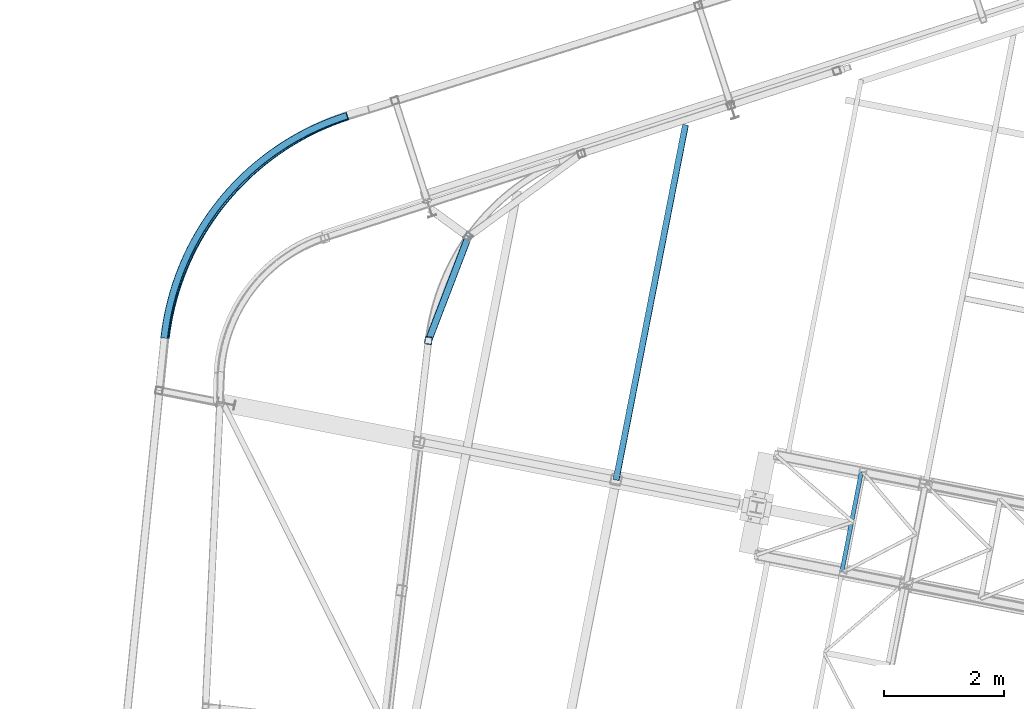
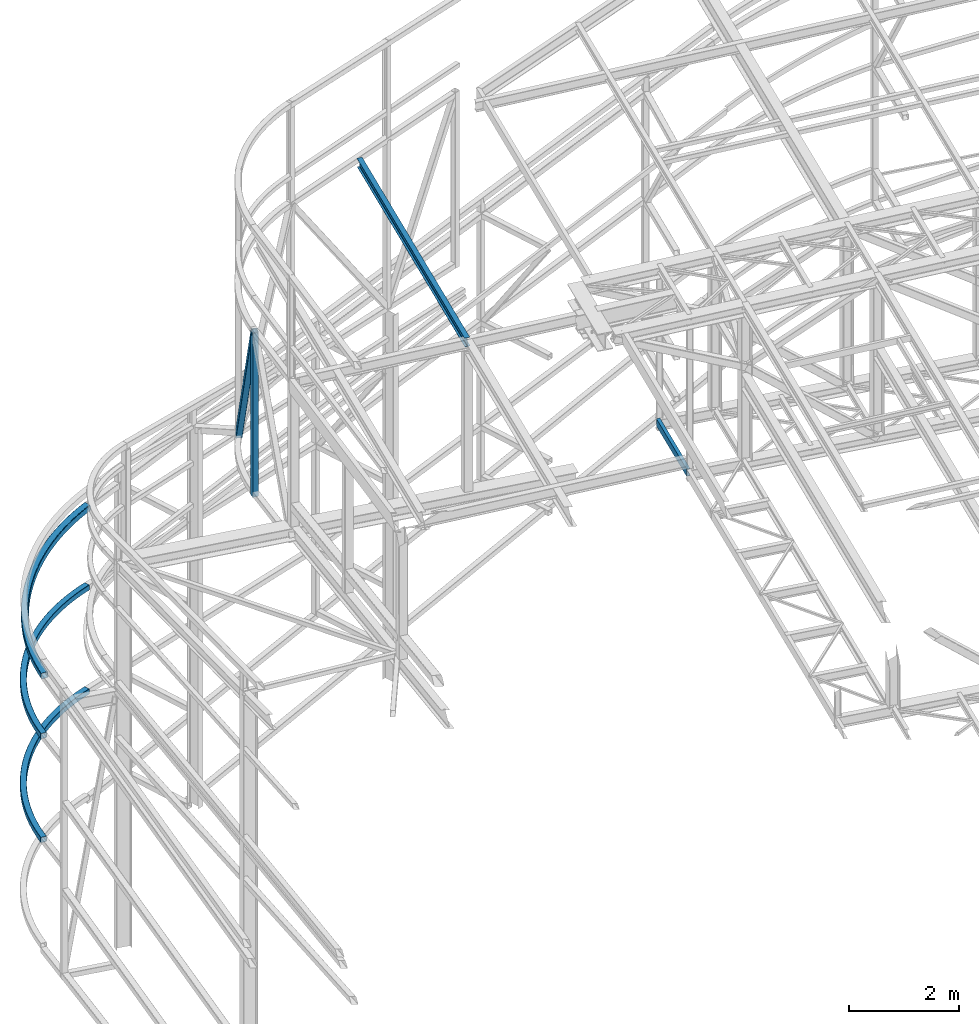
# One storey, part 78 of 215: 6 beams, 1 member, 7 elements without a shape of their own.
"""IFC2X3 building model written with IfcOpenShell, lengths in millimetres."""

from ifc_helpers import new_model, entity, si_unit, frame, origin_with_axes, origin_2d_with_axis, place, context, subcontext, project, spatial, hollow_rectangle, i_section, u_section, extrude, material, type_object, element, aggregate, save


model = new_model("IFC2X3")

# Units and contexts
model_context = context("Model", 3, precision=1e-05, world=origin_with_axes())
body_context = subcontext(model_context, "Body", "Model", "MODEL_VIEW")
ifc_project = project(units=[si_unit("LENGTHUNIT", "METRE", prefix="MILLI"), si_unit("AREAUNIT", "SQUARE_METRE"), si_unit("VOLUMEUNIT", "CUBIC_METRE"), si_unit("MASSUNIT", "GRAM", prefix="KILO"), si_unit("TIMEUNIT", "SECOND"), si_unit("PLANEANGLEUNIT", "RADIAN"), si_unit("SOLIDANGLEUNIT", "STERADIAN"), si_unit("THERMODYNAMICTEMPERATUREUNIT", "DEGREE_CELSIUS"), si_unit("LUMINOUSINTENSITYUNIT", "LUMEN")], contexts=[model_context])

# Site, building, storey
site_placement = place(None, origin_with_axes())
site = spatial("IfcSite", under=ifc_project, at=site_placement, CompositionType="ELEMENT")
building_placement = place(site_placement, origin_with_axes())
building = spatial("IfcBuilding", under=site, at=building_placement, Name="Undefined", CompositionType="ELEMENT")
storey_placement = place(building_placement, origin_with_axes())
storey = spatial("IfcBuildingStorey", under=building, at=storey_placement, Name="Undefined", CompositionType="ELEMENT", Elevation=0.0)

# Assembly, beam
assembly_1_placement = place(storey_placement, origin_with_axes())
assembly_1 = element("IfcElementAssembly", 1, at=assembly_1_placement, inside=storey, Name="Steel Assembly", AssemblyPlace="NOTDEFINED", PredefinedType="RIGID_FRAME")
ifc_material = material(Name="STEEL/S275JR")
beam_type_1 = type_object("IfcBeamType", PredefinedType="NOTDEFINED")
beam_1_placement = place(assembly_1_placement, frame((42524.7938425761, 55404.6051768975, 11885.8222207951), z_axis=(0.993324655321394, -0.115352196037323, 0.0), x_axis=(0.0, 0.0, -1.0)))
beam_1 = element("IfcBeam", 2, at=beam_1_placement, type_object=beam_type_1, material=ifc_material, Name="LISSE", context=body_context, shape_type="SweptSolid", body=[
    extrude(hollow_rectangle(XDim=120.0, YDim=120.0, WallThickness=5.0, InnerFilletRadius=5.0, OuterFilletRadius=10.0, at=origin_2d_with_axis()), frame((3650.58752308877, 0.0, 0.0), z_axis=(-1.0, 0.0, 0.0), x_axis=(-6.93889390390723e-18, -1.0, -3.46944695195361e-18)), (0.0, 0.0, 1.0), 3650.6),
])
aggregate(assembly_1, [beam_1])

assembly_2_placement = place(storey_placement, origin_with_axes())
assembly_2 = element("IfcElementAssembly", 3, at=assembly_2_placement, inside=storey, Name="Steel Assembly", AssemblyPlace="NOTDEFINED", PredefinedType="RIGID_FRAME")
beam_2_placement = place(assembly_2_placement, frame((38111.0952299367, 55446.5853241237, 4401.40044545449), z_axis=(-0.77261725510298, 0.634872095084621, 0.0), x_axis=(0.634872095084621, 0.772617255102981, 0.0)))
beam_2 = element("IfcBeam", 4, at=beam_2_placement, type_object=beam_type_1, material=ifc_material, Name="LISSE", context=body_context, shape_type="SweptSolid", body=[
    entity("IfcRevolvedAreaSolid", entity("IfcRectangleHollowProfileDef", "AREA", None, entity("IfcAxis2Placement2D", entity("IfcCartesianPoint", [0.0, 0.0]), entity("IfcDirection", [1.0, 0.0])), 120.0, 120.0, 5.0, 5.0, 10.0), entity("IfcAxis2Placement3D", entity("IfcCartesianPoint", [4806.97109428235, 0.0, 0.0]), entity("IfcDirection", [-0.836811562220839, 0.0, 0.547491013016213]), entity("IfcDirection", [-6.93889390390723e-18, -1.0, -3.46944695195361e-18])), entity("IfcAxis1Placement", entity("IfcCartesianPoint", [0.0, -4390.0, 0.0]), entity("IfcDirection", [1.0, 0.0, 0.0])), 1.15872603365599),
])
aggregate(assembly_2, [beam_2])

assembly_3_placement = place(storey_placement, origin_with_axes())
assembly_3 = element("IfcElementAssembly", 5, at=assembly_3_placement, inside=storey, Name="Steel Assembly", AssemblyPlace="NOTDEFINED", PredefinedType="RIGID_FRAME")
beam_3_placement = place(assembly_3_placement, frame((38111.102894485, 55446.6552582422, 2088.87296218641), z_axis=(-0.772612172890469, 0.634878279909991, 0.0), x_axis=(0.634878279909993, 0.772612172890467, 0.0)))
beam_3 = element("IfcBeam", 6, at=beam_3_placement, type_object=beam_type_1, material=ifc_material, Name="LISSE", context=body_context, shape_type="SweptSolid", body=[
    entity("IfcRevolvedAreaSolid", entity("IfcRectangleHollowProfileDef", "AREA", None, entity("IfcAxis2Placement2D", entity("IfcCartesianPoint", [0.0, 0.0]), entity("IfcDirection", [1.0, 0.0])), 120.0, 120.0, 5.0, 5.0, 10.0), entity("IfcAxis2Placement3D", entity("IfcCartesianPoint", [4806.91219644417, 4.54747350886464e-13, 0.0]), entity("IfcDirection", [-0.836815951067035, 0.0, 0.547484304834188]), entity("IfcDirection", [-6.93889390390723e-18, -1.0, -3.46944695195361e-18])), entity("IfcAxis1Placement", entity("IfcCartesianPoint", [0.0, -4390.0, 0.0]), entity("IfcDirection", [1.0, 0.0, 0.0])), 1.15871000097973),
])
aggregate(assembly_3, [beam_3])

# Assembly, member
assembly_4_placement = place(storey_placement, origin_with_axes())
assembly_4 = element("IfcElementAssembly", 7, at=assembly_4_placement, inside=storey, Name="Steel Assembly", AssemblyPlace="NOTDEFINED", PredefinedType="RIGID_FRAME")
member_type = type_object("IfcMemberType", PredefinedType="NOTDEFINED")
member_placement = place(assembly_4_placement, frame((42524.8147071562, 55404.7848466333, 11885.8222207942), z_axis=(-0.330114019970363, -0.825422269925897, -0.457933193958886), x_axis=(0.164024963958066, 0.427588393890684, -0.888967927772729)))
member = element("IfcMember", 8, at=member_placement, type_object=member_type, material=ifc_material, context=body_context, shape_type="SweptSolid", body=[
    extrude(hollow_rectangle(XDim=120.0, YDim=120.0, WallThickness=5.0, InnerFilletRadius=5.0, OuterFilletRadius=10.0, at=origin_2d_with_axis()), frame((4052.36682727618, 3.62743420328889e-12, 0.0), z_axis=(-1.0, 0.0, 0.0), x_axis=(-6.93889390390723e-18, -1.0, -3.46944695195361e-18)), (0.0, 0.0, 1.0), 4052.4),
])
aggregate(assembly_4, [member])

# Assembly, beam
assembly_5_placement = place(storey_placement, origin_with_axes())
assembly_5 = element("IfcElementAssembly", 9, at=assembly_5_placement, inside=storey, Name="Steel Assembly", AssemblyPlace="NOTDEFINED", PredefinedType="RIGID_FRAME")
beam_type_2 = type_object("IfcBeamType", PredefinedType="NOTDEFINED")
beam_4_placement = place(assembly_5_placement, frame((38127.0192074409, 55441.4505688214, 5738.53495214846), z_axis=(-0.092002469962016, -0.0433366039821048, 0.994815301589288), x_axis=(0.631764315126486, 0.769686882154101, 0.0919562590184108)))
beam_4 = element("IfcBeam", 10, at=beam_4_placement, type_object=beam_type_2, material=ifc_material, Name="LISSE", context=body_context, shape_type="SweptSolid", body=[
    entity("IfcRevolvedAreaSolid", entity("IfcRectangleHollowProfileDef", "AREA", None, entity("IfcAxis2Placement2D", entity("IfcCartesianPoint", [0.0, 0.0]), entity("IfcDirection", [1.0, 0.0])), 140.0, 140.0, 8.0, 12.0, 20.0), entity("IfcAxis2Placement3D", entity("IfcCartesianPoint", [4823.62395322928, -1.58469509963923e-12, -1.23784648548415e-13]), entity("IfcDirection", [-0.842720785183468, 0.538350887637198, 4.22398085323336e-18]), entity("IfcDirection", [-0.538350887637198, -0.842720785183468, 1.91662196227886e-17])), entity("IfcAxis1Placement", entity("IfcCartesianPoint", [4480.0, 0.0, 0.0]), entity("IfcDirection", [0.0, 1.0, 0.0])), 1.13695798575102),
])
aggregate(assembly_5, [beam_4])

assembly_6_placement = place(storey_placement, origin_with_axes())
assembly_6 = element("IfcElementAssembly", 11, at=assembly_6_placement, inside=storey, Name="Steel Assembly", AssemblyPlace="NOTDEFINED", PredefinedType="RIGID_FRAME")
beam_type_3 = type_object("IfcBeamType", Name="IPE200", PredefinedType="NOTDEFINED")
beam_5_placement = place(assembly_6_placement, frame((45659.5448470751, 53075.6565844271, 11952.5718121023), z_axis=(-0.0304080349967745, 0.00594450299936818, 0.999519891893966), x_axis=(0.191859470081235, 0.981422408415534, 0.0)))
beam_5 = element("IfcBeam", 12, at=beam_5_placement, type_object=beam_type_3, material=ifc_material, ObjectType="IPE200", context=body_context, shape_type="SweptSolid", body=[
    extrude(i_section(OverallWidth=100.0, OverallDepth=200.0, WebThickness=5.599999905, FlangeThickness=8.5, FilletRadius=12.0, at=origin_2d_with_axis()), frame((6047.23396542971, -2.13277535675629e-14, 1.81947759008393e-12), z_axis=(-1.0, 0.0, 0.0), x_axis=(-6.93889390390723e-18, -1.0, -3.46944695195361e-18)), (0.0, 0.0, 1.0), 6047.2),
])
aggregate(assembly_6, [beam_5])

assembly_7_placement = place(storey_placement, origin_with_axes())
assembly_7 = element("IfcElementAssembly", 13, at=assembly_7_placement, inside=storey, Name="Steel Assembly", AssemblyPlace="NOTDEFINED", PredefinedType="RIGID_FRAME")
beam_type_4 = type_object("IfcBeamType", Name="UPE160", PredefinedType="NOTDEFINED")
beam_6_placement = place(assembly_7_placement, frame((49429.1226182, 51545.6932586536, 8659.90778505302), z_axis=(0.0, 0.0, 1.0), x_axis=(0.191859470081235, 0.981422408415534, 0.0)))
beam_6 = element("IfcBeam", 14, at=beam_6_placement, type_object=beam_type_4, material=ifc_material, ObjectType="UPE160", context=body_context, shape_type="SweptSolid", body=[
    extrude(u_section(Depth=160.0, FlangeWidth=70.0, WebThickness=5.5, FlangeThickness=9.5, FilletRadius=12.0, at=origin_2d_with_axis()), frame((1699.99999941724, 1.81898940354586e-12, 0.0), z_axis=(-1.0, 0.0, 0.0), x_axis=(-6.93889390390723e-18, -1.0, -3.46944695195361e-18)), (0.0, 0.0, 1.0), 1700.0),
])
aggregate(assembly_7, [beam_6])

save(model, "model.ifc")
